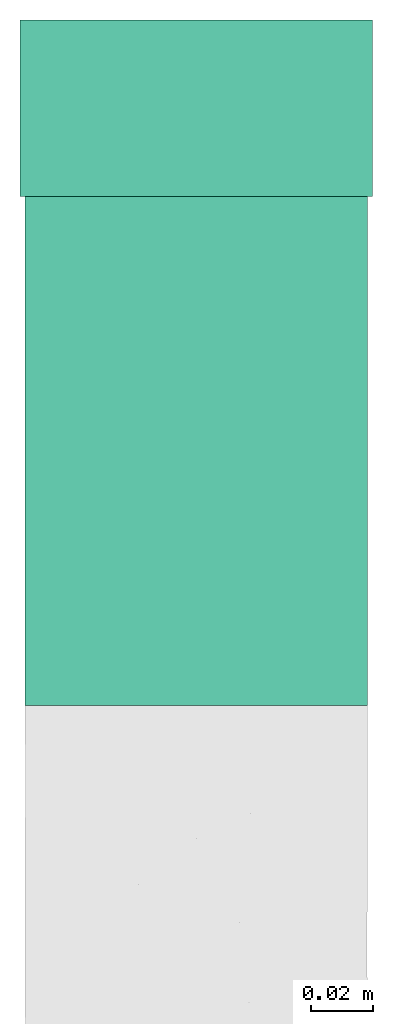
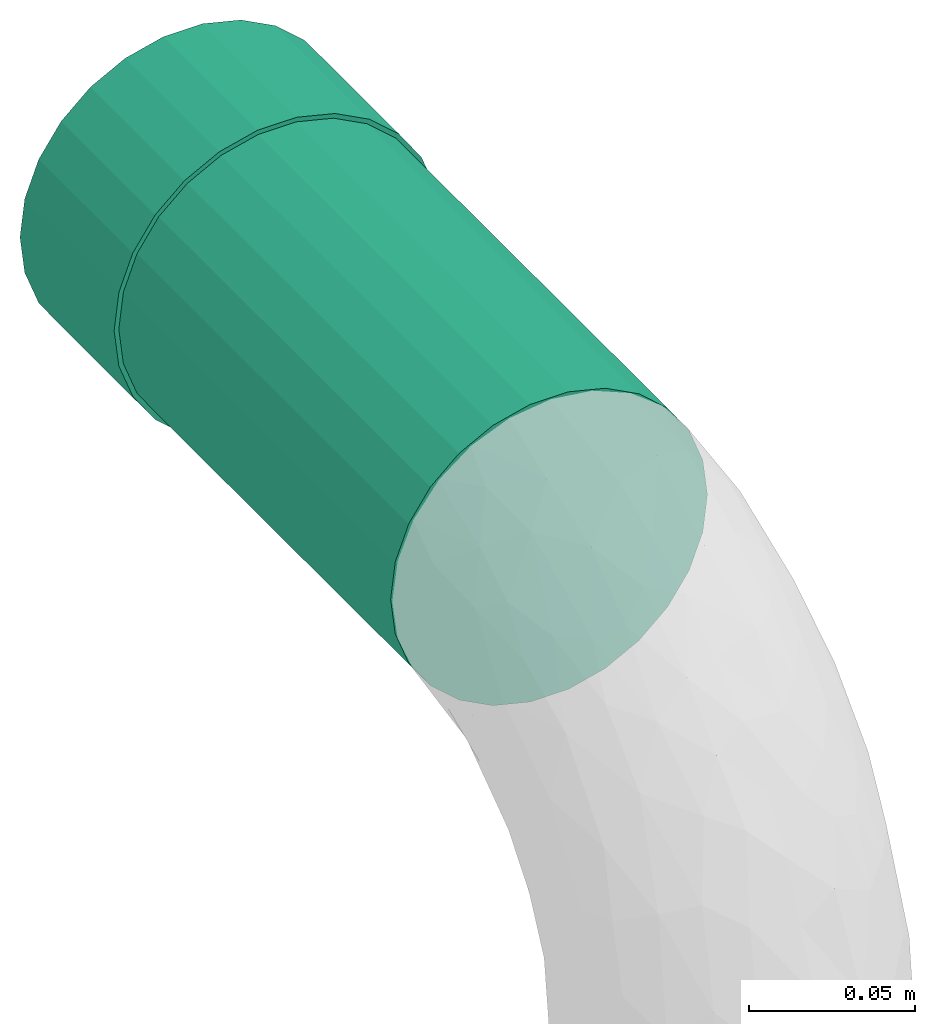
# One storey, part 1 of 2: 1 flow fitting, 1 flow segment.
"""IFC2X3 building model written with IfcOpenShell, lengths in millimetres."""

from ifc_helpers import new_model, entity, si_unit, converted_unit, derived_unit, direction, frame, frame_2d, origin, origin_2d_with_axis, place, context, subcontext, project, spatial, circle, extrude, source, transform, mapped, type_object, type_shapes, element, save


model = new_model("IFC2X3")

# Units and contexts
model_context = context("Model", 3, precision=0.01, world=origin(), true_north=direction((6.12303176911189e-17, 1.0)))
body_context = subcontext(model_context, "Body", "Model", "MODEL_VIEW")
ifc_project = project(units=[si_unit("LENGTHUNIT", "METRE", prefix="MILLI"), si_unit("AREAUNIT", "SQUARE_METRE"), si_unit("VOLUMEUNIT", "CUBIC_METRE"), converted_unit("PLANEANGLEUNIT", "DEGREE", entity("IfcRatioMeasure", 0.0174532925199433), si_unit("PLANEANGLEUNIT", "RADIAN"), dimensions=[0, 0, 0, 0, 0, 0, 0]), si_unit("MASSUNIT", "GRAM", prefix="KILO"), derived_unit("MASSDENSITYUNIT", [(si_unit("MASSUNIT", "GRAM", prefix="KILO"), 1), (si_unit("LENGTHUNIT", "METRE"), -3)]), si_unit("TIMEUNIT", "SECOND"), si_unit("FREQUENCYUNIT", "HERTZ"), si_unit("THERMODYNAMICTEMPERATUREUNIT", "DEGREE_CELSIUS"), derived_unit("THERMALTRANSMITTANCEUNIT", [(si_unit("MASSUNIT", "GRAM", prefix="KILO"), 1), (si_unit("THERMODYNAMICTEMPERATUREUNIT", "KELVIN"), -1), (si_unit("TIMEUNIT", "SECOND"), -3)]), derived_unit("VOLUMETRICFLOWRATEUNIT", [(si_unit("LENGTHUNIT", "METRE"), 3), (si_unit("TIMEUNIT", "SECOND"), -1)]), si_unit("ELECTRICCURRENTUNIT", "AMPERE"), si_unit("ELECTRICVOLTAGEUNIT", "VOLT"), si_unit("POWERUNIT", "WATT"), si_unit("FORCEUNIT", "NEWTON", prefix="KILO"), si_unit("ILLUMINANCEUNIT", "LUX"), si_unit("LUMINOUSFLUXUNIT", "LUMEN"), si_unit("LUMINOUSINTENSITYUNIT", "CANDELA"), derived_unit("USERDEFINED", [(si_unit("MASSUNIT", "GRAM", prefix="KILO"), -1), (si_unit("LENGTHUNIT", "METRE"), -2), (si_unit("TIMEUNIT", "SECOND"), 3), (si_unit("LUMINOUSFLUXUNIT", "LUMEN"), 1)]), derived_unit("LINEARVELOCITYUNIT", [(si_unit("LENGTHUNIT", "METRE"), 1), (si_unit("TIMEUNIT", "SECOND"), -1)]), si_unit("PRESSUREUNIT", "PASCAL"), derived_unit("USERDEFINED", [(si_unit("LENGTHUNIT", "METRE"), -2), (si_unit("MASSUNIT", "GRAM", prefix="KILO"), 1), (si_unit("TIMEUNIT", "SECOND"), -2)])], contexts=[model_context])

# Site, building, storey
site_placement = place(None, origin())
site = spatial("IfcSite", under=ifc_project, at=site_placement, CompositionType="ELEMENT")
building_placement = place(site_placement, origin())
building = spatial("IfcBuilding", under=site, at=building_placement, CompositionType="ELEMENT")
storey_placement = place(building_placement, frame((0.0, 0.0, 16000.0)))
storey = spatial("IfcBuildingStorey", under=building, at=storey_placement, Name="04 Roof", CompositionType="ELEMENT", Elevation=16000.0)

# Flow segment
pipe_segment_type = type_object("IfcPipeSegmentType", Name="Pipe Types", PredefinedType="NOTDEFINED")
flow_segment_placement = place(storey_placement, frame((30783.1932668086, -68050.8241905963, 943.404727764086)))
element("IfcFlowSegment", 1, at=flow_segment_placement, inside=storey, type_object=pipe_segment_type, Name="Pipe Types", ObjectType="Pipe Types", context=body_context, shape_type="SweptSolid", body=[
    extrude(circle(Radius=55.0, at=origin_2d_with_axis()), frame((56.5952722359164, 0.0, 56.5952722359164), z_axis=(0.0, 1.0, 0.0), x_axis=(1.0, 0.0, 0.0)), (0.0, 0.0, 1.0), 163.472824049353),
])

# Flow fitting
pipe_fitting_type = type_object("IfcPipeFittingType", Name="Standard", PredefinedType="NOTDEFINED")
shared_shape = source(origin(), body_context, "Body", "SweptSolid", [
    extrude(circle(Radius=56.5875, at=frame_2d((0.0, -9.1419628605704e-14), x_axis=(1.0, 0.0))), frame((-28.2937499999937, 0.0, 0.0), z_axis=(1.0, 0.0, 0.0), x_axis=(0.0, 1.0, 0.0)), (0.0, 0.0, 1.0), 56.5875),
])
type_shapes(pipe_fitting_type, [shared_shape])
flow_fitting_placement = place(storey_placement, frame((30839.7885390445, -67859.057616547, 1000.0), z_axis=(0.0, 0.0, 1.0), x_axis=(0.0, 1.0, 0.0)))
element("IfcFlowFitting", 2, at=flow_fitting_placement, inside=storey, type_object=pipe_fitting_type, Name="M_Coupling - Generic:Standard", ObjectType="M_Coupling - Generic:Standard", context=body_context, shape_type="MappedRepresentation", body=[
    mapped(shared_shape, transform((0.0, 0.0, 0.0), scale=1.0)),
])

save(model, "model.ifc")
